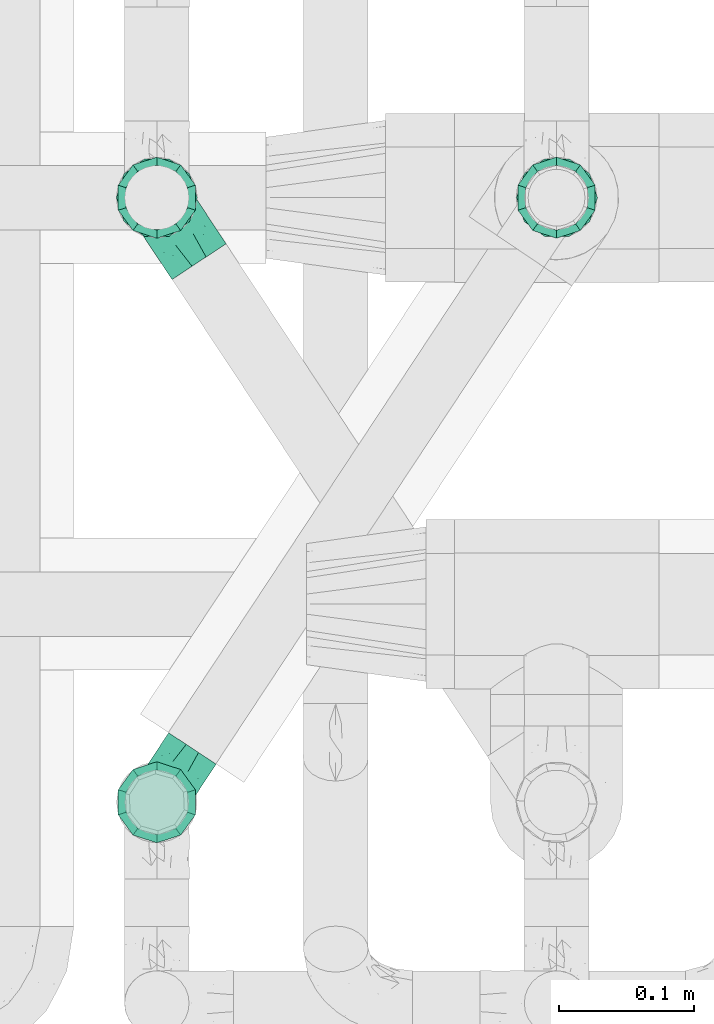
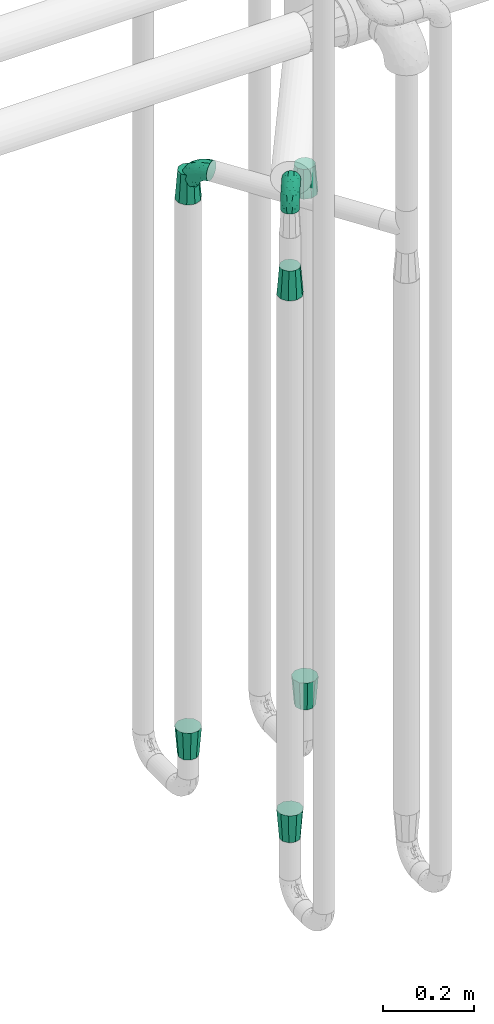
# One storey, part 666 of 827: 8 flow fittings.
"""IFC2X3 building model written with IfcOpenShell, lengths in millimetres."""

from ifc_helpers import new_model, entity, si_unit, converted_unit, derived_unit, direction, frame, origin, place, context, subcontext, project, spatial, faceted_brep, source, transform, mapped, material, type_object, type_shapes, element, save


model = new_model("IFC2X3")

# Units and contexts
model_context = context("Model", 3, precision=0.01, world=origin(), true_north=direction((6.12303176911189e-17, 1.0)))
body_context = subcontext(model_context, "Body", "Model", "MODEL_VIEW")
ifc_project = project(units=[si_unit("LENGTHUNIT", "METRE", prefix="MILLI"), si_unit("AREAUNIT", "SQUARE_METRE"), si_unit("VOLUMEUNIT", "CUBIC_METRE"), converted_unit("PLANEANGLEUNIT", "DEGREE", entity("IfcRatioMeasure", 0.0174532925199433), si_unit("PLANEANGLEUNIT", "RADIAN"), dimensions=[0, 0, 0, 0, 0, 0, 0]), si_unit("MASSUNIT", "GRAM", prefix="KILO"), derived_unit("MASSDENSITYUNIT", [(si_unit("MASSUNIT", "GRAM", prefix="KILO"), 1), (si_unit("LENGTHUNIT", "METRE"), -3)]), derived_unit("MOMENTOFINERTIAUNIT", [(si_unit("LENGTHUNIT", "METRE"), 4)]), si_unit("TIMEUNIT", "SECOND"), si_unit("FREQUENCYUNIT", "HERTZ"), si_unit("THERMODYNAMICTEMPERATUREUNIT", "DEGREE_CELSIUS"), derived_unit("THERMALTRANSMITTANCEUNIT", [(si_unit("MASSUNIT", "GRAM", prefix="KILO"), 1), (si_unit("THERMODYNAMICTEMPERATUREUNIT", "KELVIN"), -1), (si_unit("TIMEUNIT", "SECOND"), -3)]), derived_unit("VOLUMETRICFLOWRATEUNIT", [(si_unit("LENGTHUNIT", "METRE"), 3), (si_unit("TIMEUNIT", "SECOND"), -1)]), derived_unit("MASSFLOWRATEUNIT", [(si_unit("MASSUNIT", "GRAM", prefix="KILO"), 1), (si_unit("TIMEUNIT", "SECOND"), -1)]), derived_unit("ROTATIONALFREQUENCYUNIT", [(si_unit("TIMEUNIT", "SECOND"), -1)]), si_unit("ELECTRICCURRENTUNIT", "AMPERE"), si_unit("ELECTRICVOLTAGEUNIT", "VOLT"), si_unit("POWERUNIT", "WATT"), si_unit("FORCEUNIT", "NEWTON", prefix="KILO"), si_unit("ILLUMINANCEUNIT", "LUX"), si_unit("LUMINOUSFLUXUNIT", "LUMEN"), si_unit("LUMINOUSINTENSITYUNIT", "CANDELA"), derived_unit("USERDEFINED", [(si_unit("MASSUNIT", "GRAM", prefix="KILO"), -1), (si_unit("LENGTHUNIT", "METRE"), -2), (si_unit("TIMEUNIT", "SECOND"), 3), (si_unit("LUMINOUSFLUXUNIT", "LUMEN"), 1)]), derived_unit("LINEARVELOCITYUNIT", [(si_unit("LENGTHUNIT", "METRE"), 1), (si_unit("TIMEUNIT", "SECOND"), -1)]), si_unit("PRESSUREUNIT", "PASCAL"), derived_unit("USERDEFINED", [(si_unit("LENGTHUNIT", "METRE"), -2), (si_unit("MASSUNIT", "GRAM", prefix="KILO"), 1), (si_unit("TIMEUNIT", "SECOND"), -2)]), derived_unit("LINEARFORCEUNIT", [(si_unit("MASSUNIT", "GRAM", prefix="KILO"), 1), (si_unit("LENGTHUNIT", "METRE"), 1), (si_unit("TIMEUNIT", "SECOND"), -2), (si_unit("LENGTHUNIT", "METRE"), -1)]), derived_unit("PLANARFORCEUNIT", [(si_unit("MASSUNIT", "GRAM", prefix="KILO"), 1), (si_unit("LENGTHUNIT", "METRE"), 1), (si_unit("TIMEUNIT", "SECOND"), -2), (si_unit("LENGTHUNIT", "METRE"), -2)])], contexts=[model_context])

# Site, building, storey
site_placement = place(None, origin())
site = spatial("IfcSite", under=ifc_project, at=site_placement, CompositionType="ELEMENT")
building_placement = place(site_placement, origin())
building = spatial("IfcBuilding", under=site, at=building_placement, CompositionType="ELEMENT")
storey_placement = place(building_placement, frame((0.0, 0.0, 28200.0)))
storey = spatial("IfcBuildingStorey", under=building, at=storey_placement, Name="08", CompositionType="ELEMENT", Elevation=28200.0)

# Flow fittings
ifc_material = material()
pipe_fitting_type_1 = type_object("IfcPipeFittingType", Name="ADSK_1", PredefinedType="NOTDEFINED", material=ifc_material)
shared_shape_1 = source(origin(), body_context, "Body", "Brep", [
    faceted_brep([(-57.0, 12.07, -20.91), (-57.0, 6.25, -23.33), (-57.0, 0.0, -24.15), (-57.0, -6.25, -23.33), (-57.0, -12.08, -20.91), (-57.0, -17.08, -17.08), (-57.0, -20.91, -12.08), (-57.0, -23.33, -6.25), (-57.0, -24.15, 0.0), (-57.0, -23.33, 6.25), (-57.0, -20.91, 12.07), (-57.0, -17.08, 17.08), (-57.0, -12.08, 20.91), (-57.0, -6.25, 23.33), (-57.0, 0.0, 24.15), (-57.0, 6.25, 23.33), (-57.0, 12.07, 20.91), (-57.0, 17.08, 17.08), (-57.0, 20.91, 12.07), (-57.0, 23.33, 6.25), (-57.0, 24.15, 0.0), (-57.0, 23.33, -6.25), (-57.0, 20.91, -12.08), (-57.0, 17.08, -17.08), (0.0, 57.0, -24.15), (-6.25, 57.0, -23.33), (-12.07, 57.0, -20.91), (-17.08, 57.0, -17.08), (-20.91, 57.0, -12.08), (-23.33, 57.0, -6.25), (-24.15, 57.0, 0.0), (-23.33, 57.0, 6.25), (-20.91, 57.0, 12.07), (-17.08, 57.0, 17.08), (-12.07, 57.0, 20.91), (-6.25, 57.0, 23.33), (0.0, 57.0, 24.15), (6.25, 57.0, 23.33), (12.08, 57.0, 20.91), (17.08, 57.0, 17.08), (20.91, 57.0, 12.07), (23.33, 57.0, 6.25), (24.15, 57.0, 0.0), (23.33, 57.0, -6.25), (20.91, 57.0, -12.08), (17.08, 57.0, -17.08), (12.08, 57.0, -20.91), (6.25, 57.0, -23.33), (14.9, 21.14, 6.17), (13.61, 24.64, 12.48), (6.23, 8.95, 8.98), (-41.47, -21.06, 0.0), (-41.92, -18.38, 13.72), (-24.64, -13.61, 12.48), (-37.37, -13.24, 18.15), (-6.8, -4.93, 8.18), (-21.76, -15.19, 6.22), (-12.78, -9.18, 0.0), (-37.73, -20.51, 7.75), (-7.38, 7.38, 20.24), (-23.37, -4.26, 20.42), (-11.9, -3.19, 15.86), (-42.14, -8.7, 21.82), (13.24, 37.37, 18.15), (9.33, 23.53, 16.85), (4.26, 23.37, 20.42), (2.77, 10.92, 15.55), (-29.46, 0.91, 23.52), (-44.13, 20.56, 15.69), (-39.25, 26.33, 10.88), (-49.02, 22.92, 9.96), (-34.58, 23.87, 17.15), (-15.8, 6.8, 22.81), (-8.67, 20.47, 23.88), (-18.12, 12.9, 24.08), (-48.29, 14.92, 19.65), (-44.06, -2.85, 23.78), (-9.23, 48.95, 22.58), (-3.78, 42.74, 24.07), (-40.34, 4.26, 24.09), (-44.02, 26.14, 5.46), (-44.04, 9.88, 22.74), (-4.95, 16.87, 22.52), (-2.75, 1.43, 12.5), (-25.48, 40.98, 10.71), (20.51, 37.73, 7.75), (18.38, 41.92, 13.72), (8.7, 42.14, 21.82), (-25.95, -17.97, 0.0), (2.85, 44.06, 23.78), (21.06, 41.47, 0.0), (17.97, 25.95, 0.0), (-24.04, -9.27, 17.13), (-33.26, 33.26, 5.86), (-28.55, 40.57, 0.0), (-40.57, 28.55, 0.0), (-25.29, 47.19, 4.06), (-27.01, 31.1, 16.77), (-15.7, 43.95, 19.9), (-20.27, 45.22, 15.61), (-30.53, 31.98, 12.64), (-11.28, 38.33, 22.92), (-9.97, 27.88, 24.09), (-20.15, 30.26, 21.25), (-31.25, 11.75, 23.64), (-28.75, 7.23, 24.15), (-29.53, 18.06, 22.27), (-28.44, 24.21, 20.02), (-37.55, 17.7, 20.26), (-15.88, 29.25, 22.99), (-20.82, 20.82, 23.44), (-0.91, 29.46, 23.52), (-13.5, -7.67, 12.04), (1.49, 1.56, 5.16), (8.86, 10.35, 4.59), (0.38, -0.38, 0.0), (9.18, 12.78, 0.0), (-37.37, -13.24, -18.15), (8.86, 10.35, -4.59), (-45.22, 20.27, -15.61), (-43.95, 15.7, -19.9), (-38.33, 11.28, -22.92), (-48.95, 9.23, -22.58), (-47.19, 25.29, -4.06), (-33.26, 33.26, -5.86), (18.38, 41.92, -13.72), (-30.26, 20.15, -21.25), (2.85, 44.06, -23.78), (-4.26, 40.34, -24.09), (-40.98, 25.48, -10.71), (-41.92, -18.38, -13.72), (9.25, 23.5, -16.92), (4.26, 23.37, -20.42), (13.24, 37.37, -18.15), (-37.73, -20.51, -7.75), (-11.75, 31.25, -23.64), (-7.23, 28.75, -24.15), (-12.9, 18.12, -24.08), (8.7, 42.14, -21.82), (-44.06, -2.85, -23.78), (-6.8, 15.8, -22.81), (-20.47, 8.67, -23.88), (-24.64, -13.61, -12.48), (-42.74, 3.78, -24.07), (-18.06, 29.53, -22.27), (-24.21, 28.44, -20.02), (-27.88, 9.97, -24.09), (-31.1, 27.01, -16.77), (-26.14, 44.02, -5.46), (14.9, 21.14, -6.17), (20.51, 37.73, -7.75), (-9.88, 44.04, -22.74), (-20.56, 44.13, -15.69), (-21.76, -15.19, -6.22), (-13.5, -7.67, -12.04), (-24.14, -9.76, -16.74), (-11.9, -3.19, -15.86), (-14.92, 48.29, -19.65), (-23.37, -4.26, -20.42), (-0.91, 29.46, -23.52), (-26.33, 39.25, -10.88), (-23.87, 34.58, -17.15), (-42.14, -8.7, -21.82), (-22.92, 49.02, -9.96), (13.61, 24.64, -12.48), (-31.98, 30.53, -12.64), (-16.87, 4.95, -22.52), (-17.7, 37.55, -20.26), (-29.25, 15.88, -22.99), (-20.82, 20.82, -23.44), (-29.46, 0.91, -23.52), (-7.38, 7.38, -20.24), (2.77, 10.92, -15.55), (6.23, 8.95, -8.98), (-6.8, -4.93, -8.18), (-2.81, 1.41, -12.54), (1.49, 1.56, -5.16)], [[[0, 1, 2, 3, 4, 5, 6, 7, 8, 9, 10, 11, 12, 13, 14, 15, 16, 17, 18, 19, 20, 21, 22, 23]], [[24, 25, 26, 27, 28, 29, 30, 31, 32, 33, 34, 35, 36, 37, 38, 39, 40, 41, 42, 43, 44, 45, 46, 47]], [[48, 49, 50]], [[9, 8, 51]], [[52, 53, 54]], [[55, 56, 57]], [[10, 58, 52]], [[9, 58, 10]], [[59, 60, 61]], [[54, 12, 11]], [[54, 62, 12]], [[63, 39, 38]], [[64, 65, 66]], [[62, 60, 67]], [[68, 69, 70]], [[71, 69, 68]], [[72, 73, 74]], [[16, 75, 17]], [[13, 76, 14]], [[35, 77, 78]], [[14, 79, 15]], [[17, 68, 18]], [[14, 76, 79]], [[20, 19, 80]], [[70, 19, 18]], [[81, 15, 79]], [[15, 81, 16]], [[73, 72, 82]], [[66, 83, 50]], [[32, 31, 84]], [[85, 86, 49]], [[63, 87, 65]], [[56, 58, 88]], [[36, 89, 37]], [[85, 41, 40]], [[36, 35, 78]], [[90, 41, 85]], [[40, 39, 86]], [[12, 62, 13]], [[86, 85, 40]], [[48, 85, 49]], [[85, 91, 90]], [[87, 38, 37]], [[92, 60, 54]], [[80, 69, 93]], [[93, 94, 95]], [[10, 52, 11]], [[94, 96, 30]], [[97, 98, 99]], [[80, 93, 95]], [[100, 97, 84]], [[99, 98, 33]], [[101, 102, 78]], [[103, 101, 98]], [[96, 31, 30]], [[77, 98, 101]], [[77, 35, 34]], [[34, 33, 98]], [[9, 51, 58]], [[87, 63, 38]], [[104, 105, 74]], [[106, 103, 107]], [[106, 81, 104]], [[75, 68, 17]], [[108, 107, 71]], [[33, 32, 99]], [[109, 103, 110]], [[101, 109, 102]], [[89, 78, 111]], [[53, 52, 58]], [[54, 11, 52]], [[60, 62, 54]], [[88, 58, 51]], [[76, 62, 67]], [[53, 112, 92]], [[60, 59, 72]], [[39, 63, 86]], [[49, 86, 63]], [[89, 87, 37]], [[42, 41, 90]], [[111, 82, 65]], [[111, 65, 87]], [[65, 59, 66]], [[104, 81, 79]], [[75, 81, 108]], [[32, 84, 99]], [[97, 99, 84]], [[98, 97, 103]], [[106, 107, 108]], [[74, 102, 110]], [[111, 78, 102]], [[74, 110, 104]], [[74, 67, 72]], [[61, 92, 112]], [[66, 59, 61]], [[56, 53, 58]], [[66, 50, 49]], [[61, 112, 83]], [[66, 49, 64]], [[78, 89, 36]], [[87, 89, 111]], [[62, 76, 13]], [[79, 76, 67]], [[100, 93, 69]], [[96, 93, 84]], [[55, 113, 50]], [[113, 114, 50]], [[104, 79, 105]], [[106, 104, 110]], [[20, 80, 95]], [[85, 48, 91]], [[115, 114, 113]], [[116, 91, 48]], [[70, 80, 19]], [[93, 96, 94]], [[84, 31, 96]], [[103, 106, 110]], [[81, 106, 108]], [[103, 97, 107]], [[71, 107, 97]], [[71, 97, 100]], [[108, 71, 68]], [[79, 67, 105]], [[67, 74, 105]], [[115, 113, 57]], [[112, 56, 55]], [[56, 88, 57]], [[60, 72, 67]], [[82, 72, 59]], [[65, 82, 59]], [[82, 111, 73]], [[111, 102, 73]], [[102, 74, 73]], [[81, 75, 16]], [[68, 75, 108]], [[68, 70, 18]], [[80, 70, 69]], [[98, 77, 34]], [[78, 77, 101]], [[93, 100, 84]], [[71, 100, 69]], [[102, 109, 110]], [[101, 103, 109]], [[53, 92, 54]], [[61, 60, 92]], [[56, 112, 53]], [[83, 112, 55]], [[50, 83, 55]], [[61, 83, 66]], [[49, 63, 64]], [[65, 64, 63]], [[57, 113, 55]], [[114, 115, 116]], [[116, 48, 114]], [[48, 50, 114]], [[117, 5, 4]], [[116, 115, 118]], [[119, 120, 23]], [[121, 122, 120]], [[95, 123, 20]], [[0, 23, 120]], [[124, 95, 94]], [[125, 45, 44]], [[121, 120, 126]], [[24, 127, 128]], [[22, 21, 129]], [[0, 122, 1]], [[5, 117, 130]], [[131, 132, 133]], [[134, 88, 51]], [[135, 136, 137]], [[6, 5, 130]], [[46, 138, 47]], [[139, 3, 2]], [[140, 141, 137]], [[6, 134, 7]], [[134, 130, 142]], [[143, 2, 1]], [[144, 126, 145]], [[121, 146, 143]], [[147, 120, 119]], [[94, 148, 124]], [[149, 150, 91]], [[30, 29, 148]], [[151, 25, 128]], [[27, 152, 28]], [[134, 153, 88]], [[154, 155, 156]], [[27, 26, 157]], [[151, 26, 25]], [[155, 158, 156]], [[24, 47, 127]], [[1, 122, 143]], [[138, 132, 159]], [[160, 152, 161]], [[24, 128, 25]], [[46, 133, 138]], [[162, 117, 4]], [[148, 160, 124]], [[152, 160, 163]], [[154, 142, 155]], [[45, 125, 133]], [[133, 46, 45]], [[125, 164, 133]], [[51, 7, 134]], [[42, 90, 43]], [[165, 147, 129]], [[153, 134, 142]], [[43, 150, 44]], [[162, 4, 3]], [[141, 140, 166]], [[117, 162, 158]], [[163, 29, 28]], [[43, 90, 150]], [[123, 21, 20]], [[144, 151, 135]], [[157, 152, 27]], [[167, 145, 161]], [[23, 22, 119]], [[168, 126, 169]], [[121, 168, 146]], [[139, 143, 170]], [[142, 130, 117]], [[8, 7, 51]], [[134, 6, 130]], [[139, 162, 3]], [[170, 166, 158]], [[170, 158, 162]], [[158, 171, 156]], [[44, 150, 125]], [[91, 150, 90]], [[164, 125, 150]], [[132, 138, 133]], [[127, 138, 159]], [[131, 164, 172]], [[132, 171, 140]], [[135, 151, 128]], [[157, 151, 167]], [[22, 129, 119]], [[147, 119, 129]], [[120, 147, 126]], [[144, 145, 167]], [[137, 146, 169]], [[170, 143, 146]], [[137, 169, 135]], [[137, 159, 140]], [[171, 172, 156]], [[173, 174, 175]], [[156, 175, 154]], [[174, 57, 153]], [[132, 172, 171]], [[172, 164, 173]], [[143, 139, 2]], [[162, 139, 170]], [[138, 127, 47]], [[128, 127, 159]], [[165, 124, 160]], [[123, 124, 129]], [[149, 173, 164]], [[176, 174, 173]], [[135, 128, 136]], [[144, 135, 169]], [[150, 149, 164]], [[176, 118, 115]], [[149, 91, 116]], [[30, 148, 94]], [[163, 148, 29]], [[124, 123, 95]], [[129, 21, 123]], [[126, 144, 169]], [[151, 144, 167]], [[126, 147, 145]], [[161, 145, 147]], [[161, 147, 165]], [[167, 161, 152]], [[128, 159, 136]], [[159, 137, 136]], [[154, 153, 142]], [[132, 140, 159]], [[174, 176, 57]], [[57, 88, 153]], [[166, 140, 171]], [[158, 166, 171]], [[166, 170, 141]], [[170, 146, 141]], [[146, 137, 141]], [[151, 157, 26]], [[152, 157, 167]], [[152, 163, 28]], [[148, 163, 160]], [[120, 122, 0]], [[143, 122, 121]], [[124, 165, 129]], [[161, 165, 160]], [[146, 168, 169]], [[121, 126, 168]], [[142, 117, 155]], [[158, 155, 117]], [[175, 156, 172]], [[153, 154, 174]], [[173, 175, 172]], [[174, 154, 175]], [[164, 131, 133]], [[172, 132, 131]], [[176, 173, 118]], [[57, 176, 115]], [[173, 149, 118]], [[149, 116, 118]]]),
])
type_shapes(pipe_fitting_type_1, [shared_shape_1])
flow_fitting_1_placement = place(storey_placement, frame((47994.84, 14235.68, 2100.0), z_axis=(0.834213762884824, 0.55144120068557, 0.0), x_axis=(0.0, 0.0, 1.0)))
element("IfcFlowFitting", 1, at=flow_fitting_1_placement, inside=storey, type_object=pipe_fitting_type_1, material=ifc_material, Name="ADSK_1", ObjectType="ADSK_1", context=body_context, shape_type="MappedRepresentation", body=[
    mapped(shared_shape_1, transform((0.0, 0.0, 0.0), scale=1.0)),
])
pipe_fitting_type_2 = type_object("IfcPipeFittingType", Name="ADSK_1", PredefinedType="NOTDEFINED", material=ifc_material)
shared_shape_2 = source(origin(), body_context, "Body", "Brep", [
    faceted_brep([(-48.0, 10.6, -18.36), (-48.0, 5.49, -20.48), (-48.0, 0.0, -21.2), (-48.0, -5.49, -20.48), (-48.0, -10.6, -18.36), (-48.0, -14.99, -14.99), (-48.0, -18.36, -10.6), (-48.0, -20.48, -5.49), (-48.0, -21.2, 0.0), (-48.0, -20.48, 5.49), (-48.0, -18.36, 10.6), (-48.0, -14.99, 14.99), (-48.0, -10.6, 18.36), (-48.0, -5.49, 20.48), (-48.0, 0.0, 21.2), (-48.0, 5.49, 20.48), (-48.0, 10.6, 18.36), (-48.0, 14.99, 14.99), (-48.0, 18.36, 10.6), (-48.0, 20.48, 5.49), (-48.0, 21.2, 0.0), (-48.0, 20.48, -5.49), (-48.0, 18.36, -10.6), (-48.0, 14.99, -14.99), (0.0, 48.0, -21.2), (-5.49, 48.0, -20.48), (-10.6, 48.0, -18.36), (-14.99, 48.0, -14.99), (-18.36, 48.0, -10.6), (-20.48, 48.0, -5.49), (-21.2, 48.0, 0.0), (-20.48, 48.0, 5.49), (-18.36, 48.0, 10.6), (-14.99, 48.0, 14.99), (-10.6, 48.0, 18.36), (-5.49, 48.0, 20.48), (0.0, 48.0, 21.2), (5.49, 48.0, 20.48), (10.6, 48.0, 18.36), (14.99, 48.0, 14.99), (18.36, 48.0, 10.6), (20.48, 48.0, 5.49), (21.2, 48.0, 0.0), (20.48, 48.0, -5.49), (18.36, 48.0, -10.6), (14.99, 48.0, -14.99), (10.6, 48.0, -18.36), (5.49, 48.0, -20.48), (-35.25, -16.22, 12.01), (-34.76, -18.57, 0.0), (-20.87, -12.37, 10.9), (-31.49, -11.78, 15.9), (-37.0, -2.58, 20.86), (-33.89, 3.62, 21.15), (-31.81, -18.14, 6.76), (-5.78, 5.78, 17.67), (-19.42, -4.1, 17.86), (-9.6, -3.39, 13.73), (-35.44, -7.73, 19.13), (11.78, 31.49, 15.9), (-5.93, -5.46, 6.95), (-18.45, -13.78, 5.46), (-10.29, -8.43, 0.0), (-24.6, 0.55, 20.62), (-37.28, 17.94, 13.81), (-33.38, 22.85, 9.59), (-41.46, 20.06, 8.75), (-29.51, 20.45, 15.16), (-15.04, 10.79, 21.13), (-7.08, 16.98, 20.93), (-8.39, 23.51, 21.15), (-40.86, 13.03, 17.26), (-8.05, 41.26, 19.83), (-3.21, 35.97, 21.14), (8.53, 19.66, 14.74), (4.1, 19.42, 17.86), (-37.72, 22.66, 4.78), (-37.07, 8.58, 19.98), (-13.0, 5.43, 19.97), (-3.78, 13.93, 19.7), (3.02, 8.69, 13.43), (-2.27, -0.05, 10.65), (6.22, 6.99, 7.09), (-22.25, 34.6, 9.45), (18.14, 31.81, 6.76), (16.22, 35.25, 12.01), (12.37, 20.87, 10.9), (7.73, 35.44, 19.13), (-21.52, -15.93, 0.0), (2.58, 37.0, 20.86), (18.57, 34.76, 0.0), (13.78, 18.45, 5.46), (15.93, 21.52, 0.0), (-20.03, -8.54, 14.9), (-28.6, 28.6, 5.16), (-24.79, 34.6, 0.0), (-34.6, 24.79, 0.0), (-22.81, 37.41, 4.68), (-23.36, 26.33, 14.79), (-13.68, 37.05, 17.49), (-17.72, 38.12, 13.73), (-26.25, 27.3, 11.24), (-9.71, 32.34, 20.14), (-17.26, 25.6, 18.71), (-26.33, 9.99, 20.77), (-24.06, 6.05, 21.2), (-25.02, 15.46, 19.56), (-24.3, 20.72, 17.57), (-31.95, 15.23, 17.8), (-13.53, 24.7, 20.21), (-17.6, 17.6, 20.6), (-0.55, 24.6, 20.62), (-11.41, -7.48, 10.43), (0.93, -0.93, 0.0), (8.43, 10.29, 0.0), (-11.41, -7.48, -10.43), (-20.1, -8.84, -14.66), (-9.6, -3.39, -13.73), (7.73, 35.44, -19.13), (4.1, 19.42, -17.86), (-0.55, 24.6, -20.62), (-38.12, 17.72, -13.73), (-37.05, 13.68, -17.49), (-32.34, 9.71, -20.14), (-41.26, 8.05, -19.83), (-37.41, 22.81, -4.68), (-23.51, 8.39, -21.15), (-35.97, 3.21, -21.14), (-28.6, 28.6, -5.16), (-31.81, -18.14, -6.76), (-18.45, -13.78, -5.46), (-25.6, 17.26, -18.71), (-19.42, -4.1, -17.86), (-17.94, 37.28, -13.81), (-22.85, 33.38, -9.59), (-20.06, 41.46, -8.75), (-31.49, -11.78, -15.9), (-35.25, -16.22, -12.01), (8.53, 19.66, -14.74), (11.78, 31.49, -15.9), (-9.99, 26.33, -20.77), (-6.05, 24.06, -21.2), (-10.79, 15.04, -21.13), (-37.0, -2.58, -20.86), (-16.98, 7.08, -20.93), (-5.43, 13.0, -19.97), (-13.93, 3.78, -19.7), (-20.87, -12.37, -10.9), (-26.33, 23.36, -14.79), (-22.66, 37.72, -4.78), (13.78, 18.45, -5.46), (18.14, 31.81, -6.76), (-15.46, 25.02, -19.56), (-20.72, 24.3, -17.57), (16.22, 35.25, -12.01), (-13.03, 40.86, -17.26), (-8.58, 37.07, -19.98), (2.58, 37.0, -20.86), (-3.62, 33.89, -21.15), (-34.6, 22.25, -9.45), (6.22, 6.99, -7.09), (-20.45, 29.51, -15.16), (-35.44, -7.73, -19.13), (12.37, 20.87, -10.9), (-27.3, 26.25, -11.24), (-15.23, 31.95, -17.8), (-24.7, 13.53, -20.21), (-24.6, 0.55, -20.62), (-5.78, 5.78, -17.67), (-17.6, 17.6, -20.6), (3.02, 8.69, -13.43), (-5.93, -5.46, -6.95), (-2.27, -0.05, -10.65)], [[[0, 1, 2, 3, 4, 5, 6, 7, 8, 9, 10, 11, 12, 13, 14, 15, 16, 17, 18, 19, 20, 21, 22, 23]], [[24, 25, 26, 27, 28, 29, 30, 31, 32, 33, 34, 35, 36, 37, 38, 39, 40, 41, 42, 43, 44, 45, 46, 47]], [[10, 48, 11]], [[9, 8, 49]], [[48, 50, 51]], [[14, 52, 53]], [[10, 54, 48]], [[9, 54, 10]], [[55, 56, 57]], [[51, 12, 11]], [[51, 58, 12]], [[59, 39, 38]], [[60, 61, 62]], [[58, 56, 63]], [[64, 65, 66]], [[67, 65, 64]], [[68, 69, 70]], [[16, 71, 17]], [[13, 52, 14]], [[35, 72, 73]], [[14, 53, 15]], [[17, 64, 18]], [[74, 59, 75]], [[20, 19, 76]], [[66, 19, 18]], [[77, 15, 53]], [[15, 77, 16]], [[69, 78, 79]], [[80, 81, 82]], [[32, 31, 83]], [[84, 85, 86]], [[59, 87, 75]], [[61, 54, 88]], [[36, 89, 37]], [[84, 41, 40]], [[36, 35, 73]], [[90, 41, 84]], [[40, 39, 85]], [[12, 58, 13]], [[85, 84, 40]], [[91, 84, 86]], [[84, 92, 90]], [[87, 38, 37]], [[93, 56, 51]], [[65, 94, 76]], [[94, 95, 96]], [[84, 91, 92]], [[95, 97, 30]], [[98, 99, 100]], [[76, 94, 96]], [[101, 98, 83]], [[100, 99, 33]], [[102, 70, 73]], [[103, 102, 99]], [[94, 97, 95]], [[72, 99, 102]], [[72, 35, 34]], [[34, 33, 99]], [[9, 49, 54]], [[87, 59, 38]], [[104, 105, 68]], [[106, 103, 107]], [[106, 77, 104]], [[71, 64, 17]], [[108, 107, 67]], [[33, 32, 100]], [[109, 103, 110]], [[102, 109, 70]], [[89, 73, 111]], [[50, 48, 54]], [[51, 11, 48]], [[56, 58, 51]], [[88, 54, 49]], [[52, 58, 63]], [[50, 112, 93]], [[56, 55, 78]], [[39, 59, 85]], [[86, 85, 59]], [[89, 87, 37]], [[42, 41, 90]], [[111, 79, 75]], [[111, 75, 87]], [[75, 55, 80]], [[104, 77, 53]], [[71, 77, 108]], [[32, 83, 100]], [[98, 100, 83]], [[99, 98, 103]], [[106, 107, 108]], [[68, 70, 110]], [[111, 73, 70]], [[68, 110, 104]], [[68, 63, 78]], [[57, 93, 112]], [[80, 55, 57]], [[61, 50, 54]], [[80, 82, 86]], [[81, 57, 112]], [[74, 86, 59]], [[60, 113, 82]], [[82, 114, 91]], [[101, 94, 65]], [[97, 94, 83]], [[73, 89, 36]], [[87, 89, 111]], [[58, 52, 13]], [[53, 52, 63]], [[104, 53, 105]], [[106, 104, 110]], [[20, 76, 96]], [[76, 19, 66]], [[103, 106, 110]], [[77, 106, 108]], [[103, 98, 107]], [[67, 107, 98]], [[67, 98, 101]], [[108, 67, 64]], [[53, 63, 105]], [[63, 68, 105]], [[83, 31, 97]], [[30, 97, 31]], [[62, 113, 60]], [[112, 61, 60]], [[61, 88, 62]], [[86, 82, 91]], [[56, 78, 63]], [[114, 82, 113]], [[114, 92, 91]], [[79, 78, 55]], [[75, 79, 55]], [[69, 79, 111]], [[70, 69, 111]], [[78, 69, 68]], [[77, 71, 16]], [[64, 71, 108]], [[64, 66, 18]], [[76, 66, 65]], [[99, 72, 34]], [[73, 72, 102]], [[94, 101, 83]], [[67, 101, 65]], [[75, 80, 74]], [[80, 86, 74]], [[70, 109, 110]], [[102, 103, 109]], [[50, 93, 51]], [[57, 56, 93]], [[61, 112, 50]], [[81, 112, 60]], [[82, 81, 60]], [[80, 57, 81]], [[115, 116, 117]], [[118, 119, 120]], [[121, 122, 23]], [[123, 124, 122]], [[96, 125, 20]], [[123, 126, 127]], [[128, 96, 95]], [[129, 130, 88]], [[123, 122, 131]], [[116, 132, 117]], [[133, 134, 135]], [[0, 124, 1]], [[5, 136, 137]], [[138, 119, 139]], [[129, 88, 49]], [[140, 141, 142]], [[6, 5, 137]], [[46, 118, 47]], [[143, 3, 2]], [[144, 145, 146]], [[6, 129, 7]], [[129, 137, 147]], [[127, 2, 1]], [[148, 122, 121]], [[128, 125, 96]], [[134, 128, 149]], [[95, 149, 128]], [[150, 151, 92]], [[30, 29, 149]], [[152, 131, 153]], [[27, 133, 28]], [[154, 45, 44]], [[136, 5, 4]], [[27, 26, 155]], [[156, 26, 25]], [[24, 157, 158]], [[24, 47, 157]], [[22, 21, 159]], [[160, 150, 114]], [[134, 133, 161]], [[142, 144, 126]], [[46, 139, 118]], [[162, 136, 4]], [[156, 25, 158]], [[1, 124, 127]], [[115, 147, 116]], [[45, 154, 139]], [[139, 46, 45]], [[154, 163, 139]], [[162, 4, 3]], [[42, 90, 43]], [[130, 129, 147]], [[49, 7, 129]], [[43, 151, 44]], [[0, 23, 122]], [[24, 158, 25]], [[136, 162, 132]], [[135, 29, 28]], [[43, 90, 151]], [[164, 148, 159]], [[152, 156, 140]], [[155, 133, 27]], [[165, 153, 161]], [[23, 22, 121]], [[123, 131, 166]], [[123, 166, 126]], [[143, 127, 167]], [[147, 137, 136]], [[8, 7, 49]], [[129, 6, 137]], [[143, 162, 3]], [[167, 146, 132]], [[167, 132, 162]], [[132, 168, 117]], [[44, 151, 154]], [[92, 151, 90]], [[163, 154, 151]], [[119, 118, 139]], [[157, 118, 120]], [[138, 139, 163]], [[119, 168, 145]], [[140, 156, 158]], [[155, 156, 165]], [[22, 159, 121]], [[148, 121, 159]], [[122, 148, 131]], [[152, 153, 165]], [[142, 126, 169]], [[167, 127, 126]], [[142, 169, 140]], [[142, 120, 145]], [[168, 170, 117]], [[160, 171, 172]], [[115, 172, 171]], [[171, 62, 130]], [[119, 170, 168]], [[170, 163, 160]], [[150, 163, 151]], [[113, 171, 160]], [[164, 128, 134]], [[125, 128, 159]], [[127, 143, 2]], [[162, 143, 167]], [[118, 157, 47]], [[158, 157, 120]], [[140, 158, 141]], [[152, 140, 169]], [[30, 149, 95]], [[149, 29, 135]], [[131, 152, 169]], [[156, 152, 165]], [[131, 148, 153]], [[161, 153, 148]], [[161, 148, 164]], [[165, 161, 133]], [[158, 120, 141]], [[120, 142, 141]], [[159, 21, 125]], [[20, 125, 21]], [[115, 130, 147]], [[114, 113, 160]], [[62, 171, 113]], [[62, 88, 130]], [[160, 163, 150]], [[150, 92, 114]], [[119, 145, 120]], [[146, 145, 168]], [[132, 146, 168]], [[144, 146, 167]], [[126, 144, 167]], [[145, 144, 142]], [[156, 155, 26]], [[133, 155, 165]], [[133, 135, 28]], [[149, 135, 134]], [[122, 124, 0]], [[127, 124, 123]], [[128, 164, 159]], [[161, 164, 134]], [[163, 170, 138]], [[170, 119, 138]], [[131, 169, 166]], [[126, 166, 169]], [[147, 136, 116]], [[132, 116, 136]], [[172, 115, 117]], [[130, 115, 171]], [[117, 170, 172]], [[160, 172, 170]]]),
])
type_shapes(pipe_fitting_type_2, [shared_shape_2])
flow_fitting_2_placement = place(storey_placement, frame((47994.84, 13786.19, 2300.0), z_axis=(0.834363602116207, -0.551214458685246, 0.0), x_axis=(-0.551214458685246, -0.834363602116207, 0.0)))
element("IfcFlowFitting", 2, at=flow_fitting_2_placement, inside=storey, type_object=pipe_fitting_type_2, material=ifc_material, Name="ADSK_1", ObjectType="ADSK_1", context=body_context, shape_type="MappedRepresentation", body=[
    mapped(shared_shape_2, transform((0.0, 0.0, 0.0), scale=1.0)),
])
pipe_fitting_type_3 = type_object("IfcPipeFittingType", Name="ADSK_1", PredefinedType="NOTDEFINED", material=ifc_material)
shared_shape_3 = source(origin(), body_context, "Body", "Brep", [
    faceted_brep([(76.0, 24.15, 0.0), (76.0, 21.84, 7.1), (76.0, 19.54, 14.2), (76.0, 13.5, 18.58), (76.0, 7.46, 22.97), (76.0, 0.0, 22.97), (76.0, -7.46, 22.97), (76.0, -13.5, 18.58), (76.0, -19.54, 14.2), (76.0, -21.84, 7.1), (76.0, -24.15, 0.0), (76.0, -21.84, -7.1), (76.0, -19.54, -14.2), (76.0, -13.5, -18.58), (76.0, -7.46, -22.97), (76.0, 0.0, -22.97), (76.0, 7.46, -22.97), (76.0, 13.5, -18.58), (76.0, 19.54, -14.2), (76.0, 21.84, -7.1), (0.0, -30.15, 0.0), (0.0, -27.27, 8.86), (0.0, -24.39, 17.72), (0.0, -16.85, 23.2), (0.0, -9.32, 28.67), (0.0, 0.0, 28.67), (0.0, 9.32, 28.67), (0.0, 16.85, 23.2), (0.0, 24.39, 17.72), (0.0, 26.33, 11.75), (0.0, 28.24, 5.87), (0.0, 30.15, 0.0), (0.0, 27.27, -8.86), (0.0, 24.39, -17.72), (0.0, 16.85, -23.2), (0.0, 9.32, -28.67), (0.0, 0.0, -28.67), (0.0, -9.32, -28.67), (0.0, -16.85, -23.2), (0.0, -24.39, -17.72), (0.0, -26.33, -11.75), (0.0, -28.24, -5.87)], [[[0, 1, 2, 3, 4, 5, 6, 7, 8, 9, 10, 11, 12, 13, 14, 15, 16, 17, 18, 19]], [[20, 21, 22, 23, 24, 25, 26, 27, 28, 29, 30, 31, 32, 33, 34, 35, 36, 37, 38, 39, 40, 41]], [[19, 18, 33, 32, 31, 0]], [[36, 35, 16, 15, 14, 37]], [[35, 34, 33, 18, 17, 16]], [[41, 40, 39, 12, 11, 10, 20]], [[14, 13, 12, 39, 38, 37]], [[9, 8, 22, 21, 20, 10]], [[25, 24, 6, 5, 4, 26]], [[24, 23, 22, 8, 7, 6]], [[30, 29, 28, 2, 1, 0, 31]], [[4, 3, 2, 28, 27, 26]]]),
])
type_shapes(pipe_fitting_type_3, [shared_shape_3])
for number, where, z_axis, x_axis, name in (
    (3, (47994.84, 13786.19, 2024.0), (1.0, 0.0, 0.0), (0.0, 0.0, 1.0), "ADSK_1"),
    (4, (48292.02, 14235.68, 1921.5), (1.0, 0.0, 0.0), (0.0, 0.0, 1.0), "ADSK_1"),
    (5, (47994.84, 14235.68, 2010.0), (1.0, 0.0, 0.0), (0.0, 0.0, 1.0), "ADSK_1"),
):
    element("IfcFlowFitting", number, at=place(storey_placement, frame(where, z_axis=z_axis, x_axis=x_axis)), inside=storey, type_object=pipe_fitting_type_3, material=ifc_material, Name=name, ObjectType="ADSK_1", context=body_context, shape_type="MappedRepresentation", body=[
        mapped(shared_shape_3, transform((0.0, 0.0, 0.0), scale=1.0)),
    ])
pipe_fitting_type_4 = type_object("IfcPipeFittingType", Name="ADSK_1", PredefinedType="NOTDEFINED", material=ifc_material)
shared_shape_4 = source(origin(), body_context, "Body", "Brep", [
    faceted_brep([(76.0, -30.15, 0.0), (76.0, -28.24, -5.87), (76.0, -26.33, -11.75), (76.0, -24.39, -17.72), (76.0, -16.85, -23.2), (76.0, -9.32, -28.67), (76.0, 0.0, -28.67), (76.0, 9.32, -28.67), (76.0, 16.85, -23.2), (76.0, 24.39, -17.72), (76.0, 26.33, -11.75), (76.0, 28.24, -5.87), (76.0, 30.15, 0.0), (76.0, 28.24, 5.87), (76.0, 26.33, 11.75), (76.0, 24.39, 17.72), (76.0, 16.85, 23.2), (76.0, 9.32, 28.67), (76.0, 0.0, 28.67), (76.0, -9.32, 28.67), (76.0, -16.85, 23.2), (76.0, -24.39, 17.72), (76.0, -26.33, 11.75), (76.0, -28.24, 5.87), (0.0, -19.54, -14.2), (0.0, -21.84, -7.1), (0.0, -24.15, 0.0), (0.0, -21.84, 7.1), (0.0, -19.54, 14.2), (0.0, -13.5, 18.58), (0.0, -7.46, 22.97), (0.0, 0.0, 22.97), (0.0, 7.46, 22.97), (0.0, 13.5, 18.58), (0.0, 19.54, 14.2), (0.0, 21.84, 7.1), (0.0, 24.15, 0.0), (0.0, 21.84, -7.1), (0.0, 19.54, -14.2), (0.0, 13.5, -18.58), (0.0, 7.46, -22.97), (0.0, 0.0, -22.97), (0.0, -7.46, -22.97), (0.0, -13.5, -18.58)], [[[0, 1, 2, 3, 4, 5, 6, 7, 8, 9, 10, 11, 12, 13, 14, 15, 16, 17, 18, 19, 20, 21, 22, 23]], [[24, 25, 26, 27, 28, 29, 30, 31, 32, 33, 34, 35, 36, 37, 38, 39, 40, 41, 42, 43]], [[24, 3, 2, 1, 0, 26, 25]], [[7, 40, 39, 38, 9, 8]], [[42, 5, 4, 3, 24, 43]], [[6, 5, 42, 41, 40, 7]], [[11, 10, 9, 38, 37, 36, 12]], [[34, 15, 14, 13, 12, 36, 35]], [[19, 30, 29, 28, 21, 20]], [[32, 17, 16, 15, 34, 33]], [[18, 17, 32, 31, 30, 19]], [[23, 22, 21, 28, 27, 26, 0]]]),
])
type_shapes(pipe_fitting_type_4, [shared_shape_4])
for number, where, z_axis, x_axis, name in (
    (6, (47994.84, 13786.19, 560.0), (1.0, 0.0, 0.0), (0.0, 0.0, 1.0), "ADSK_1"),
    (7, (47994.84, 14235.68, 510.0), (0.0, 1.0, 0.0), (0.0, 0.0, 1.0), "ADSK_1"),
    (8, (48292.34, 14235.68, 541.02), (0.0, 1.0, 0.0), (0.0, 0.0, 1.0), "ADSK_1"),
):
    element("IfcFlowFitting", number, at=place(storey_placement, frame(where, z_axis=z_axis, x_axis=x_axis)), inside=storey, type_object=pipe_fitting_type_4, material=ifc_material, Name=name, ObjectType="ADSK_1", context=body_context, shape_type="MappedRepresentation", body=[
        mapped(shared_shape_4, transform((0.0, 0.0, 0.0), scale=1.0)),
    ])

save(model, "model.ifc")
